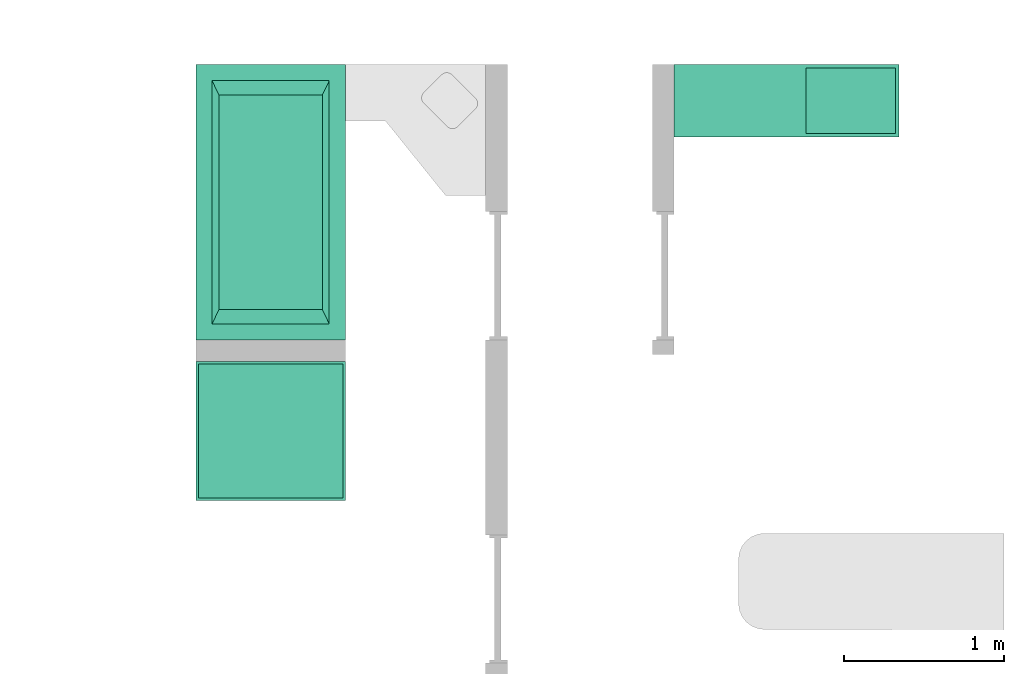
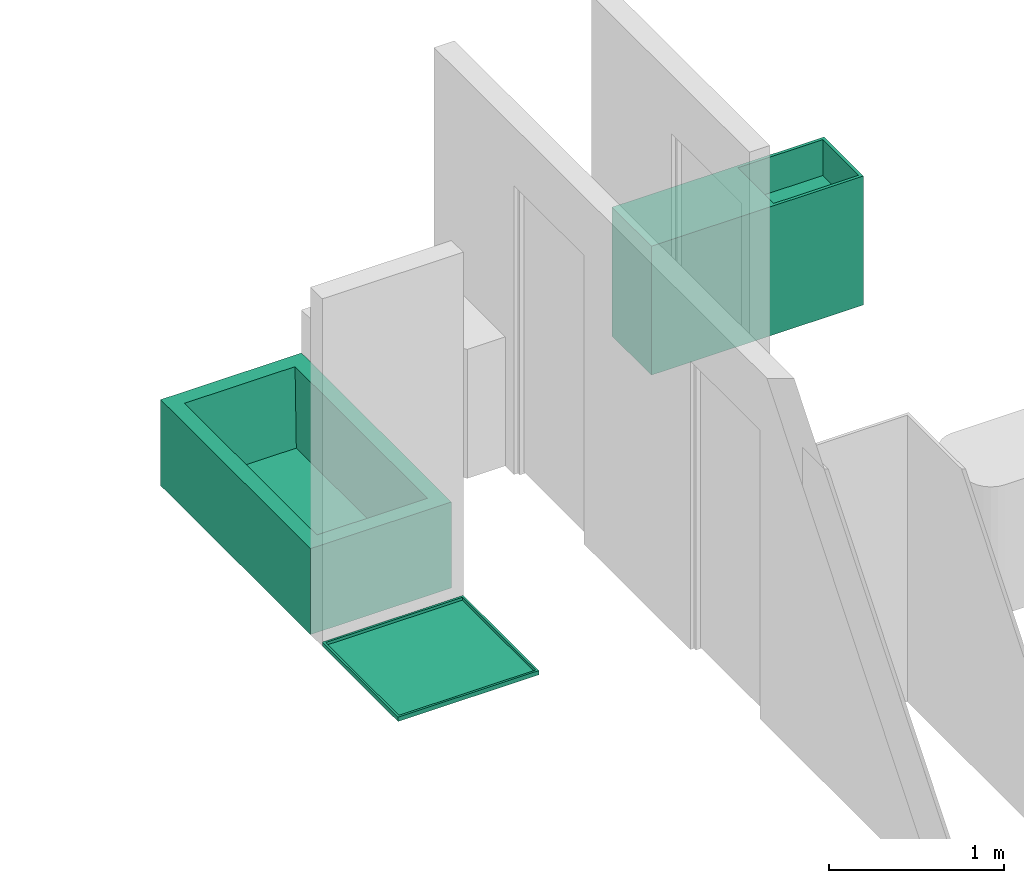
# One storey, part 5 of 6: 2 sanitary terminals, 1 actuator.
"""IFC4 building model written with IfcOpenShell, lengths in millimetres."""

from ifc_helpers import new_model, entity, si_unit, converted_unit, frame, origin_with_axes, origin_2d_with_axis, place, context, subcontext, project, spatial, polygons, source, transform, mapped, type_object, type_shapes, element, save


model = new_model("IFC4")

# Units and contexts
model_context = context("Model", 3, precision=1e-05, world=origin_with_axes())
plan_context = context("Plan", 2, precision=1e-05, world=origin_2d_with_axis())
body_context = subcontext(model_context, "Body", "Model", "MODEL_VIEW")
ifc_project = project(units=[si_unit("VOLUMEUNIT", "CUBIC_METRE"), si_unit("LENGTHUNIT", "METRE", prefix="MILLI"), converted_unit("PLANEANGLEUNIT", "degree", entity("IfcReal", 0.0174532925199433), si_unit("PLANEANGLEUNIT", "RADIAN"), dimensions=[0, 0, 0, 0, 0, 0, 0]), si_unit("AREAUNIT", "SQUARE_METRE")], contexts=[model_context, plan_context])

# Site, building, storey
site_placement = place(None, origin_with_axes())
site = spatial("IfcSite", under=ifc_project, at=site_placement)
building_placement = place(site_placement, origin_with_axes())
building = spatial("IfcBuilding", under=site, at=building_placement, Name="Building")
storey_placement = place(building_placement, origin_with_axes())
storey = spatial("IfcBuildingStorey", under=building, at=storey_placement, Name="DEMO")

# Sanitary terminals
sanitary_terminal_type_1 = type_object("IfcSanitaryTerminalType", Name="Cube", PredefinedType="BATH")
shared_shape_1 = source(origin_with_axes(), body_context, "Body", "Tessellation", [
    polygons([(-465.0, -857.499938964844, -300.0), (-365.000030517578, -757.5, 300.0), (-465.0, 857.499938964844, -300.0), (-365.000030517578, 757.5, 300.0), (465.0, -857.499938964844, -300.0), (365.000030517578, -757.5, 300.0), (465.0, 857.499938964844, -300.0), (365.000030517578, 757.5, 300.0), (-465.0, -857.499938964844, 300.0), (-465.0, 857.499938964844, 300.0), (465.0, 857.499938964844, 300.0), (465.0, -857.499938964844, 300.0), (-322.599426269531, -669.504272460938, -199.999969482422), (-322.599426269531, 669.504272460938, -199.999969482422), (322.599426269531, 669.504272460938, -199.999969482422), (322.599426269531, -669.504272460938, -199.999969482422)], [[[1, 9, 10, 3]], [[3, 10, 11, 7]], [[7, 11, 12, 5]], [[5, 12, 9, 1]], [[3, 7, 5, 1]], [[2, 6, 16, 13]], [[2, 4, 10, 9]], [[4, 8, 11, 10]], [[8, 6, 12, 11]], [[6, 2, 9, 12]], [[15, 14, 13, 16]], [[8, 4, 14, 15]], [[6, 8, 15, 16]], [[4, 2, 13, 14]]], closed=True),
])
type_shapes(sanitary_terminal_type_1, [shared_shape_1])
sanitary_terminal_1_placement = place(storey_placement, frame((8639.12010192871, 4604.16793823242, 300.000011920929), z_axis=(0.0, 0.0, 1.0), x_axis=(1.0, 0.0, 0.0)))
element("IfcSanitaryTerminal", 1, at=sanitary_terminal_1_placement, inside=storey, type_object=sanitary_terminal_type_1, Name="SanitaryTerminal", context=body_context, shape_type="MappedRepresentation", body=[
    mapped(shared_shape_1, transform((0.0, 0.0, 0.0), x_axis=(1.0, 0.0, 0.0), y_axis=(0.0, 1.0, 0.0), z_axis=(0.0, 0.0, 1.0), scale=1.0)),
])
sanitary_terminal_type_2 = type_object("IfcSanitaryTerminalType", PredefinedType="SHOWER")
shared_shape_2 = source(origin_with_axes(), body_context, "Body", "Tessellation", [
    polygons([(-465.0, -465.0, -15.0), (-451.050018310547, -451.050018310547, 15.0), (-465.0, 399.999725341797, -15.0), (-451.050018310547, 386.049713134766, 15.0), (465.0, -465.0, -15.0), (451.050018310547, -451.050018310547, 15.0), (465.0, 399.999725341797, -15.0), (451.050018310547, 386.049713134766, 15.0), (-465.0, -465.0, 15.0), (-465.0, 399.999725341797, 15.0), (465.0, 399.999725341797, 15.0), (465.0, -465.0, 15.0), (-451.050018310547, -451.050018310547, -5.00000047683716), (-451.050018310547, 386.049713134766, -5.00000047683716), (451.050018310547, 386.049713134766, -5.00000047683716), (451.050018310547, -451.050018310547, -5.00000047683716)], [[[1, 9, 10, 3]], [[3, 10, 11, 7]], [[7, 11, 12, 5]], [[5, 12, 9, 1]], [[3, 7, 5, 1]], [[2, 6, 16, 13]], [[2, 4, 10, 9]], [[4, 8, 11, 10]], [[8, 6, 12, 11]], [[6, 2, 9, 12]], [[15, 14, 13, 16]], [[8, 4, 14, 15]], [[6, 8, 15, 16]], [[4, 2, 13, 14]]], closed=True),
])
type_shapes(sanitary_terminal_type_2, [shared_shape_2])
sanitary_terminal_2_placement = place(storey_placement, frame((8639.12010192871, 3211.66729927063, 14.9999856948853), z_axis=(0.0, 0.0, 1.0), x_axis=(1.0, 0.0, 0.0)))
element("IfcSanitaryTerminal", 2, at=sanitary_terminal_2_placement, inside=storey, type_object=sanitary_terminal_type_2, Name="SanitaryTerminal", context=body_context, shape_type="MappedRepresentation", body=[
    mapped(shared_shape_2, transform((0.0, 0.0, 0.0), x_axis=(1.0, 0.0, 0.0), y_axis=(0.0, 1.0, 0.0), z_axis=(0.0, 0.0, 1.0), scale=1.0)),
])

# Actuator
actuator_placement = place(storey_placement, frame((11554.1200637817, 5236.66715621948, 450.00022649765), z_axis=(0.0, 0.0, 1.0), x_axis=(1.0, 0.0, 0.0)))
element("IfcActuator", 3, at=actuator_placement, inside=storey, Name="Cube", PredefinedType="ELECTRICACTUATOR", context=body_context, shape_type="Tessellation", body=[
    polygons([(-399.999969482422, -225.0, -450.0), (-399.999969482422, -225.0, 450.0), (-399.999969482422, 225.0, -450.0), (-399.999969482422, 225.0, 450.0), (399.999969482422, -225.0, -450.0), (399.999969482422, -225.0, 450.0), (399.999969482422, 225.0, -450.0), (399.999969482422, 225.0, 450.0), (399.998504638672, -225.000427246094, -450.0), (419.998474121094, -205.000427246094, 450.0), (399.998504638672, 224.999557495117, -450.0), (419.998474121094, 204.999572753906, 450.0), (999.998474121094, -225.000427246094, -450.0), (979.998352050781, -205.000427246094, 450.0), (999.998474121094, 224.999557495117, -450.0), (979.998352050781, 204.999572753906, 450.0), (399.998504638672, -225.000427246094, 450.0), (399.998504638672, 224.999557495117, 450.0), (999.998474121094, 224.999557495117, 450.0), (999.998474121094, -225.000427246094, 450.0), (419.998474121094, -205.000427246094, 199.999984741211), (419.998474121094, 204.999572753906, 199.999984741211), (979.998352050781, 204.999572753906, 199.999984741211), (979.998352050781, -205.000427246094, 199.999984741211)], [[[1, 2, 4, 3]], [[3, 4, 8, 7]], [[7, 8, 6, 5]], [[5, 6, 2, 1]], [[3, 7, 5, 1]], [[8, 4, 2, 6]], [[9, 17, 18, 11]], [[11, 18, 19, 15]], [[15, 19, 20, 13]], [[13, 20, 17, 9]], [[11, 15, 13, 9]], [[10, 14, 24, 21]], [[10, 12, 18, 17]], [[12, 16, 19, 18]], [[16, 14, 20, 19]], [[14, 10, 17, 20]], [[23, 22, 21, 24]], [[16, 12, 22, 23]], [[14, 16, 23, 24]], [[12, 10, 21, 22]]], closed=True),
])

save(model, "model.ifc")
